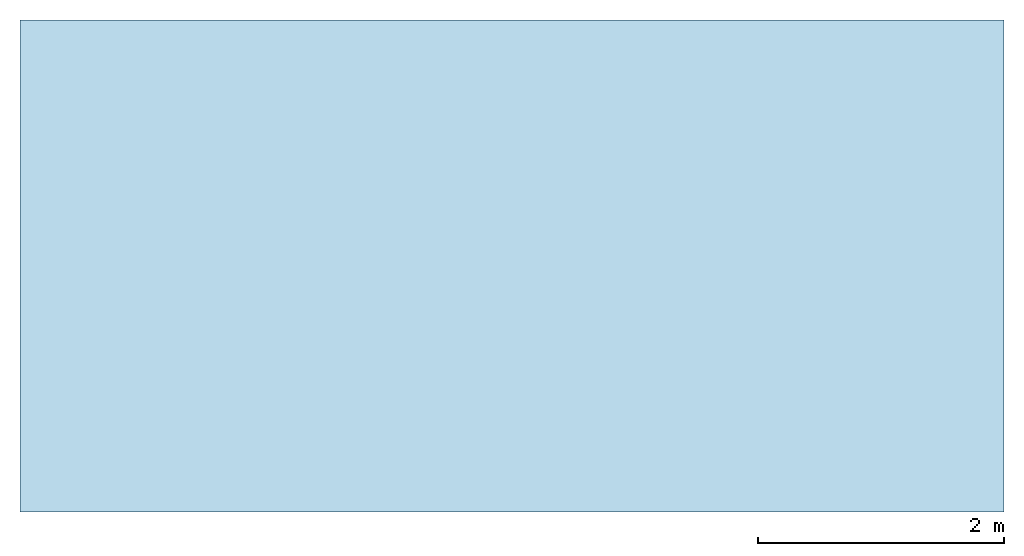
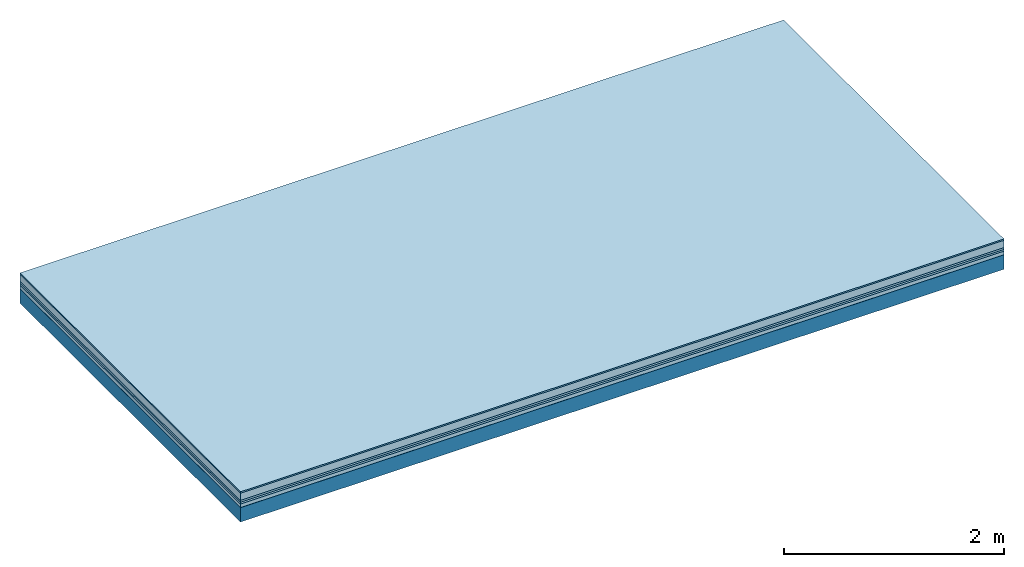
# One storey: 6 plates, 1 member, 1 element without a shape of its own.
"""IFC4 building model written with IfcOpenShell, lengths in metres."""

from ifc_helpers import new_model, si_unit, derived_unit, direction, frame, frame_2d, origin, origin_with_axes, place, context, project, spatial, rectangle, extrude, material, layer, layer_set, type_object, element, aggregate, save


model = new_model("IFC4")

# Units and contexts
plan_context = context("Plan", 3, precision=1e-05, world=origin(), true_north=direction((0.0, 1.0)))
model_context = context("Model", 3, precision=1e-05, world=origin(), true_north=direction((0.0, 1.0)))
ifc_project = project(units=[si_unit("LENGTHUNIT", "METRE"), derived_unit("SOUNDPRESSUREUNIT", [(si_unit("PRESSUREUNIT", "PASCAL", prefix="MICRO"), 0)]), si_unit("ENERGYUNIT", "JOULE", prefix="MEGA"), si_unit("MASSUNIT", "GRAM", prefix="KILO"), derived_unit("THERMALTRANSMITTANCEUNIT", [(si_unit("POWERUNIT", "WATT"), 1), (si_unit("AREAUNIT", "SQUARE_METRE"), -1), (si_unit("THERMODYNAMICTEMPERATUREUNIT", "KELVIN"), -1)]), derived_unit("AREADENSITYUNIT", [(si_unit("MASSUNIT", "GRAM", prefix="KILO"), 1), (si_unit("AREAUNIT", "SQUARE_METRE"), -1)]), derived_unit("USERDEFINED", [(si_unit("ENERGYUNIT", "JOULE", prefix="MEGA"), 1), (si_unit("AREAUNIT", "SQUARE_METRE"), -1)])], contexts=[plan_context, model_context])

# Site, building, storey
site = spatial("IfcSite", under=ifc_project)
building_placement = place(None, origin())
building = spatial("IfcBuilding", under=site, at=building_placement)
storey_placement = place(building_placement, origin())
storey = spatial("IfcBuildingStorey", under=building, at=storey_placement)

# Slab, member, plates
ifc_material_1 = material(Category="11.013")
ifc_layer_1 = layer(ifc_material_1, 0.015, Name="Flooring")
ifc_material_2 = material(Name="Cement screed", Category="04.006")
ifc_layer_2 = layer(ifc_material_2, 0.08, Name="On-material")
ifc_material_3 = material(Name="Wood fiber generic product", Category="10.009")
ifc_layer_3 = layer(ifc_material_3, 0.02, Name="Impact sound insulation")
ifc_material_4 = material()
ifc_layer_4 = layer(ifc_material_4, 0.02, Name="Additional insulation")
ifc_material_5 = material(Name="Cement panels, glued on sub-floor", Category="02.007")
ifc_layer_5 = layer(ifc_material_5, 0.04, Name="on Supporting structure")
ifc_material_6 = material(Name="protection", Category="09.007")
ifc_layer_6 = layer(ifc_material_6, 0.0005, Name="Sub-floor")
ifc_material_7 = material(Name="no composite action")
ifc_layer_7 = layer(ifc_material_7, 0.0, Name="Bond")
ifc_layer_8 = layer(None, 0.16, Name="Supporting structure")
ifc_layer_set = layer_set([ifc_layer_1, ifc_layer_2, ifc_layer_3, ifc_layer_4, ifc_layer_5, ifc_layer_6, ifc_layer_7, ifc_layer_8])
slab_type = type_object("IfcSlabType", Name="A2089", PredefinedType="NOTDEFINED", material=ifc_layer_set)
slab_placement = place(None, frame((0.0, 0.0, 0.0), z_axis=(0.0, 0.0, -1.0), x_axis=(1.0, 0.0, 0.0)))
slab = element("IfcSlab", 1, at=slab_placement, inside=storey, type_object=slab_type, material=ifc_layer_set, Name="Slab #1")
ifc_material_8 = material(Name="Solid timber panel")
member_placement = place(slab_placement, origin())
member = element("IfcMember", 2, at=member_placement, material=ifc_material_8, Name="Supporting structure", context=plan_context, shape_type="SweptSolid", body=[
    extrude(rectangle(XDim=1.0, YDim=0.16, at=frame_2d((0.5, 0.08), x_axis=(1.0, 0.0))), frame((0.0, 4.0, 0.1755), z_axis=(0.0, -1.0, 0.0), x_axis=(1.0, 0.0, 0.0)), (0.0, 0.0, 1.0), 4.0),
    extrude(rectangle(XDim=1.0, YDim=0.16, at=frame_2d((0.5, 0.08), x_axis=(1.0, 0.0))), frame((1.0, 4.0, 0.1755), z_axis=(0.0, -1.0, 0.0), x_axis=(1.0, 0.0, 0.0)), (0.0, 0.0, 1.0), 4.0),
    extrude(rectangle(XDim=1.0, YDim=0.16, at=frame_2d((0.5, 0.08), x_axis=(1.0, 0.0))), frame((2.0, 4.0, 0.1755), z_axis=(0.0, -1.0, 0.0), x_axis=(1.0, 0.0, 0.0)), (0.0, 0.0, 1.0), 4.0),
    extrude(rectangle(XDim=1.0, YDim=0.16, at=frame_2d((0.5, 0.08), x_axis=(1.0, 0.0))), frame((3.0, 4.0, 0.1755), z_axis=(0.0, -1.0, 0.0), x_axis=(1.0, 0.0, 0.0)), (0.0, 0.0, 1.0), 4.0),
    extrude(rectangle(XDim=1.0, YDim=0.16, at=frame_2d((0.5, 0.08), x_axis=(1.0, 0.0))), frame((4.0, 4.0, 0.1755), z_axis=(0.0, -1.0, 0.0), x_axis=(1.0, 0.0, 0.0)), (0.0, 0.0, 1.0), 4.0),
    extrude(rectangle(XDim=1.0, YDim=0.16, at=frame_2d((0.5, 0.08), x_axis=(1.0, 0.0))), frame((5.0, 4.0, 0.1755), z_axis=(0.0, -1.0, 0.0), x_axis=(1.0, 0.0, 0.0)), (0.0, 0.0, 1.0), 4.0),
    extrude(rectangle(XDim=1.0, YDim=0.16, at=frame_2d((0.5, 0.08), x_axis=(1.0, 0.0))), frame((6.0, 4.0, 0.1755), z_axis=(0.0, -1.0, 0.0), x_axis=(1.0, 0.0, 0.0)), (0.0, 0.0, 1.0), 4.0),
    extrude(rectangle(XDim=1.0, YDim=0.16, at=frame_2d((0.5, 0.08), x_axis=(1.0, 0.0))), frame((7.0, 4.0, 0.1755), z_axis=(0.0, -1.0, 0.0), x_axis=(1.0, 0.0, 0.0)), (0.0, 0.0, 1.0), 4.0),
])
plate_1_placement = place(slab_placement, origin())
plate_1 = element("IfcPlate", 3, at=plate_1_placement, material=ifc_material_1, Name="Flooring", context=plan_context, shape_type="SweptSolid", body=[
    extrude(rectangle(XDim=8.0, YDim=4.0, at=frame_2d((4.0, 2.0), x_axis=(1.0, 0.0))), origin_with_axes(), (0.0, 0.0, 1.0), 0.015),
])
plate_2_placement = place(slab_placement, origin())
plate_2 = element("IfcPlate", 4, at=plate_2_placement, material=ifc_material_2, Name="On-material", context=plan_context, shape_type="SweptSolid", body=[
    extrude(rectangle(XDim=8.0, YDim=4.0, at=frame_2d((4.0, 2.0), x_axis=(1.0, 0.0))), frame((0.0, 0.0, 0.015), z_axis=(0.0, 0.0, 1.0), x_axis=(1.0, 0.0, 0.0)), (0.0, 0.0, 1.0), 0.08),
])
plate_3_placement = place(slab_placement, origin())
plate_3 = element("IfcPlate", 5, at=plate_3_placement, material=ifc_material_3, Name="Impact sound insulation", context=plan_context, shape_type="SweptSolid", body=[
    extrude(rectangle(XDim=8.0, YDim=4.0, at=frame_2d((4.0, 2.0), x_axis=(1.0, 0.0))), frame((0.0, 0.0, 0.095), z_axis=(0.0, 0.0, 1.0), x_axis=(1.0, 0.0, 0.0)), (0.0, 0.0, 1.0), 0.02),
])
plate_4_placement = place(slab_placement, origin())
plate_4 = element("IfcPlate", 6, at=plate_4_placement, material=ifc_material_4, Name="Additional insulation", context=plan_context, shape_type="SweptSolid", body=[
    extrude(rectangle(XDim=8.0, YDim=4.0, at=frame_2d((4.0, 2.0), x_axis=(1.0, 0.0))), frame((0.0, 0.0, 0.115), z_axis=(0.0, 0.0, 1.0), x_axis=(1.0, 0.0, 0.0)), (0.0, 0.0, 1.0), 0.02),
])
plate_5_placement = place(slab_placement, origin())
plate_5 = element("IfcPlate", 7, at=plate_5_placement, material=ifc_material_5, Name="on Supporting structure", context=plan_context, shape_type="SweptSolid", body=[
    extrude(rectangle(XDim=8.0, YDim=4.0, at=frame_2d((4.0, 2.0), x_axis=(1.0, 0.0))), frame((0.0, 0.0, 0.135), z_axis=(0.0, 0.0, 1.0), x_axis=(1.0, 0.0, 0.0)), (0.0, 0.0, 1.0), 0.04),
])
plate_6_placement = place(slab_placement, origin())
plate_6 = element("IfcPlate", 8, at=plate_6_placement, material=ifc_material_6, Name="Sub-floor", context=plan_context, shape_type="SweptSolid", body=[
    extrude(rectangle(XDim=8.0, YDim=4.0, at=frame_2d((4.0, 2.0), x_axis=(1.0, 0.0))), frame((0.0, 0.0, 0.175), z_axis=(0.0, 0.0, 1.0), x_axis=(1.0, 0.0, 0.0)), (0.0, 0.0, 1.0), 0.0005),
])
aggregate(slab, [plate_1, plate_2, plate_3, plate_4, plate_5, plate_6, member])

save(model, "model.ifc")
